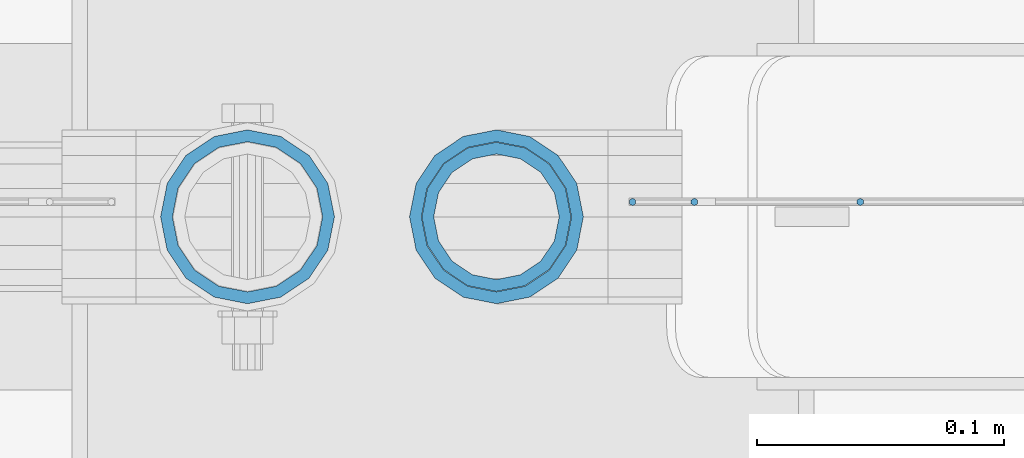
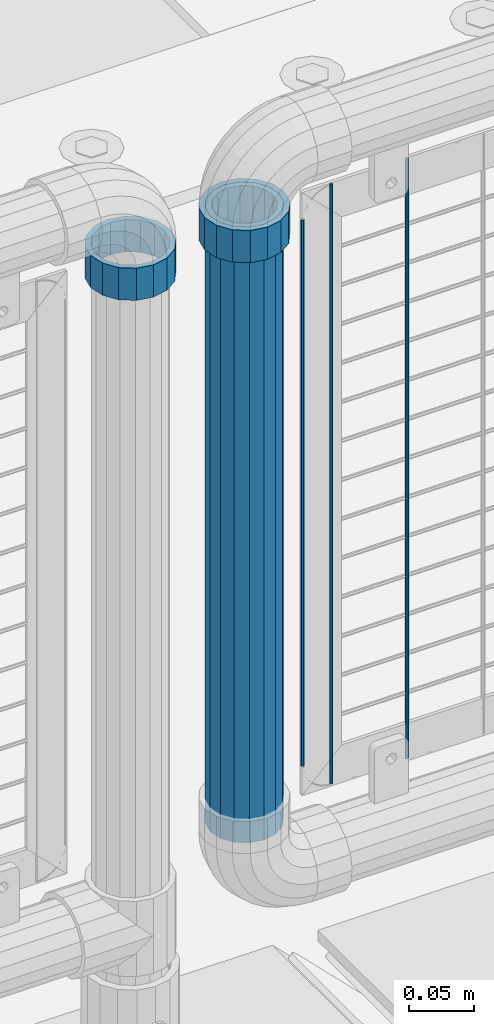
# One storey, part 98 of 257: 6 columns.
"""IFC2X3 building model written with IfcOpenShell, lengths in millimetres."""

from ifc_helpers import new_model, si_unit, frame, origin_with_axes, place, context, subcontext, project, spatial, faceted_brep, material, type_object, element, save


model = new_model("IFC2X3")

# Units and contexts
model_context = context("Model", 3, precision=1e-05, world=origin_with_axes())
body_context = subcontext(model_context, "Body", "Model", "MODEL_VIEW")
ifc_project = project(units=[si_unit("LENGTHUNIT", "METRE", prefix="MILLI"), si_unit("AREAUNIT", "SQUARE_METRE"), si_unit("VOLUMEUNIT", "CUBIC_METRE"), si_unit("MASSUNIT", "GRAM", prefix="KILO"), si_unit("TIMEUNIT", "SECOND"), si_unit("PLANEANGLEUNIT", "RADIAN"), si_unit("SOLIDANGLEUNIT", "STERADIAN"), si_unit("THERMODYNAMICTEMPERATUREUNIT", "DEGREE_CELSIUS"), si_unit("LUMINOUSINTENSITYUNIT", "LUMEN")], contexts=[model_context])

# Site, building, storey
site_placement = place(None, origin_with_axes())
site = spatial("IfcSite", under=ifc_project, at=site_placement, CompositionType="ELEMENT")
building_placement = place(site_placement, origin_with_axes())
building = spatial("IfcBuilding", under=site, at=building_placement, Name="Standard", CompositionType="ELEMENT")
storey_placement = place(building_placement, origin_with_axes())
storey = spatial("IfcBuildingStorey", under=building, at=storey_placement, Name="Undefined", CompositionType="ELEMENT", Elevation=0.0)

# Columns
ifc_material_1 = material(Name="Misc_Undefined")
column_type_1 = type_object("IfcColumnType", PredefinedType="NOTDEFINED")
column_1_placement = place(storey_placement, frame((57571.61, 10664.5, 894.849999999999), z_axis=(-1.0, 0.0, 0.0), x_axis=(0.0, 0.0, 1.0)))
element("IfcColumn", 1, at=column_1_placement, inside=storey, type_object=column_type_1, material=ifc_material_1, context=body_context, shape_type="Brep", body=[
    faceted_brep([(0.0, -30.3500000000004, 0.0), (0.0, -28.0397438117179, 11.6144421722784), (30.0, -28.0397438117179, 11.6144421722805), (30.0, -30.3500000000004, 0.0), (0.0, -21.4606908090118, 21.4606908090136), (30.0, -21.4606908090118, 21.4606908090117), (0.0, -11.6144421722802, 28.0397438117143), (30.0, -11.6144421722802, 28.0397438117175), (0.0, 0.0, 30.3499999999985), (30.0, 0.0, 30.35), (0.0, 11.6144421722802, 28.0397438117143), (30.0, 11.6144421722802, 28.0397438117175), (0.0, 21.4606908090118, 21.4606908090136), (30.0, 21.4606908090118, 21.4606908090117), (0.0, 28.0397438117179, 11.6144421722784), (30.0, 28.0397438117179, 11.6144421722805), (0.0, 30.3500000000004, 0.0), (30.0, 30.3500000000004, 0.0), (0.0, 28.0397438117179, -11.6144421722784), (30.0, 28.0397438117179, -11.6144421722805), (0.0, 21.4606908090118, -21.4606908090136), (30.0, 21.4606908090118, -21.4606908090117), (0.0, 11.6144421722802, -28.0397438117143), (30.0, 11.6144421722802, -28.0397438117175), (0.0, 0.0, -30.3499999999985), (30.0, 0.0, -30.35), (0.0, -11.6144421722802, -28.0397438117143), (30.0, -11.6144421722802, -28.0397438117175), (0.0, -21.4606908090118, -21.4606908090136), (30.0, -21.4606908090118, -21.4606908090117), (0.0, -28.0397438117179, -11.6144421722784), (30.0, -28.0397438117179, -11.6144421722805), (0.0, -35.1499999999996, 0.0), (0.0, -32.4743655677721, -13.4513226476338), (30.0, -32.4743655677721, -13.4513226476329), (30.0, -35.1499999999996, 0.0), (0.0, -24.8548033587067, -24.8548033587067), (30.0, -24.8548033587067, -24.8548033587072), (0.0, -13.4513226476338, -32.4743655677739), (30.0, -13.4513226476338, -32.4743655677717), (0.0, 0.0, -35.1499999999996), (30.0, 0.0, -35.15), (0.0, 13.4513226476338, -32.4743655677739), (30.0, 13.4513226476338, -32.4743655677717), (0.0, 24.8548033587067, -24.8548033587067), (30.0, 24.8548033587067, -24.8548033587072), (0.0, 32.4743655677721, -13.4513226476338), (30.0, 32.4743655677721, -13.4513226476329), (0.0, 35.1499999999996, 0.0), (30.0, 35.1499999999996, 0.0), (0.0, 32.4743655677721, 13.4513226476338), (30.0, 32.4743655677721, 13.4513226476329), (0.0, 24.8548033587067, 24.8548033587067), (30.0, 24.8548033587067, 24.8548033587072), (0.0, 13.4513226476338, 32.4743655677739), (30.0, 13.4513226476338, 32.4743655677717), (0.0, 0.0, 35.1499999999996), (30.0, 0.0, 35.15), (0.0, -13.4513226476338, 32.4743655677739), (30.0, -13.4513226476338, 32.4743655677717), (0.0, -24.8548033587067, 24.8548033587067), (30.0, -24.8548033587067, 24.8548033587072), (0.0, -32.4743655677721, 13.4513226476338), (30.0, -32.4743655677721, 13.4513226476329)], [[[0, 1, 2, 3]], [[1, 4, 5, 2]], [[4, 6, 7, 5]], [[6, 8, 9, 7]], [[8, 10, 11, 9]], [[10, 12, 13, 11]], [[12, 14, 15, 13]], [[14, 16, 17, 15]], [[16, 18, 19, 17]], [[18, 20, 21, 19]], [[20, 22, 23, 21]], [[22, 24, 25, 23]], [[24, 26, 27, 25]], [[26, 28, 29, 27]], [[28, 30, 31, 29]], [[30, 0, 3, 31]], [[32, 33, 34, 35]], [[33, 36, 37, 34]], [[36, 38, 39, 37]], [[38, 40, 41, 39]], [[40, 42, 43, 41]], [[42, 44, 45, 43]], [[44, 46, 47, 45]], [[46, 48, 49, 47]], [[48, 50, 51, 49]], [[50, 52, 53, 51]], [[52, 54, 55, 53]], [[54, 56, 57, 55]], [[56, 58, 59, 57]], [[58, 60, 61, 59]], [[60, 62, 63, 61]], [[62, 32, 35, 63]], [[37, 39, 41, 43, 45, 47, 49, 51, 53, 55, 57, 59, 61, 63, 35, 34], [5, 7, 9, 11, 13, 15, 17, 19, 21, 23, 25, 27, 29, 31, 3, 2]], [[62, 60, 58, 56, 54, 52, 50, 48, 46, 44, 42, 40, 38, 36, 33, 32], [30, 28, 26, 24, 22, 20, 18, 16, 14, 12, 10, 8, 6, 4, 1, 0]]]),
])
column_2_placement = place(storey_placement, frame((57471.0, 10664.5, 894.85), z_axis=(1.0, 0.0, 0.0), x_axis=(0.0, 0.0, 1.0)))
element("IfcColumn", 2, at=column_2_placement, inside=storey, type_object=column_type_1, material=ifc_material_1, context=body_context, shape_type="Brep", body=[
    faceted_brep([(0.0, -30.3500000000004, 0.0), (0.0, -28.0397438117179, 11.6144421722784), (30.0, -28.0397438117179, 11.6144421722805), (30.0, -30.3500000000004, 0.0), (0.0, -21.4606908090118, 21.4606908090136), (30.0, -21.4606908090118, 21.4606908090117), (0.0, -11.6144421722802, 28.0397438117143), (30.0, -11.6144421722802, 28.0397438117175), (0.0, 0.0, 30.3499999999985), (30.0, 0.0, 30.35), (0.0, 11.6144421722802, 28.0397438117143), (30.0, 11.6144421722802, 28.0397438117175), (0.0, 21.4606908090118, 21.4606908090136), (30.0, 21.4606908090118, 21.4606908090117), (0.0, 28.0397438117179, 11.6144421722784), (30.0, 28.0397438117179, 11.6144421722805), (0.0, 30.3500000000004, 0.0), (30.0, 30.3500000000004, 0.0), (0.0, 28.0397438117179, -11.6144421722784), (30.0, 28.0397438117179, -11.6144421722805), (0.0, 21.4606908090118, -21.4606908090136), (30.0, 21.4606908090118, -21.4606908090117), (0.0, 11.6144421722802, -28.0397438117143), (30.0, 11.6144421722802, -28.0397438117175), (0.0, 0.0, -30.3499999999985), (30.0, 0.0, -30.35), (0.0, -11.6144421722802, -28.0397438117143), (30.0, -11.6144421722802, -28.0397438117175), (0.0, -21.4606908090118, -21.4606908090136), (30.0, -21.4606908090118, -21.4606908090117), (0.0, -28.0397438117179, -11.6144421722784), (30.0, -28.0397438117179, -11.6144421722805), (0.0, -35.1499999999996, 0.0), (0.0, -32.4743655677721, -13.4513226476338), (30.0, -32.4743655677721, -13.4513226476329), (30.0, -35.1499999999996, 0.0), (0.0, -24.8548033587067, -24.8548033587067), (30.0, -24.8548033587067, -24.8548033587072), (0.0, -13.4513226476338, -32.4743655677739), (30.0, -13.4513226476338, -32.4743655677717), (0.0, 0.0, -35.1499999999996), (30.0, 0.0, -35.15), (0.0, 13.4513226476338, -32.4743655677739), (30.0, 13.4513226476338, -32.4743655677717), (0.0, 24.8548033587067, -24.8548033587067), (30.0, 24.8548033587067, -24.8548033587072), (0.0, 32.4743655677721, -13.4513226476338), (30.0, 32.4743655677721, -13.4513226476329), (0.0, 35.1499999999996, 0.0), (30.0, 35.1499999999996, 0.0), (0.0, 32.4743655677721, 13.4513226476338), (30.0, 32.4743655677721, 13.4513226476329), (0.0, 24.8548033587067, 24.8548033587067), (30.0, 24.8548033587067, 24.8548033587072), (0.0, 13.4513226476338, 32.4743655677739), (30.0, 13.4513226476338, 32.4743655677717), (0.0, 0.0, 35.1499999999996), (30.0, 0.0, 35.15), (0.0, -13.4513226476338, 32.4743655677739), (30.0, -13.4513226476338, 32.4743655677717), (0.0, -24.8548033587067, 24.8548033587067), (30.0, -24.8548033587067, 24.8548033587072), (0.0, -32.4743655677721, 13.4513226476338), (30.0, -32.4743655677721, 13.4513226476329)], [[[0, 1, 2, 3]], [[1, 4, 5, 2]], [[4, 6, 7, 5]], [[6, 8, 9, 7]], [[8, 10, 11, 9]], [[10, 12, 13, 11]], [[12, 14, 15, 13]], [[14, 16, 17, 15]], [[16, 18, 19, 17]], [[18, 20, 21, 19]], [[20, 22, 23, 21]], [[22, 24, 25, 23]], [[24, 26, 27, 25]], [[26, 28, 29, 27]], [[28, 30, 31, 29]], [[30, 0, 3, 31]], [[32, 33, 34, 35]], [[33, 36, 37, 34]], [[36, 38, 39, 37]], [[38, 40, 41, 39]], [[40, 42, 43, 41]], [[42, 44, 45, 43]], [[44, 46, 47, 45]], [[46, 48, 49, 47]], [[48, 50, 51, 49]], [[50, 52, 53, 51]], [[52, 54, 55, 53]], [[54, 56, 57, 55]], [[56, 58, 59, 57]], [[58, 60, 61, 59]], [[60, 62, 63, 61]], [[62, 32, 35, 63]], [[37, 39, 41, 43, 45, 47, 49, 51, 53, 55, 57, 59, 61, 63, 35, 34], [5, 7, 9, 11, 13, 15, 17, 19, 21, 23, 25, 27, 29, 31, 3, 2]], [[62, 60, 58, 56, 54, 52, 50, 48, 46, 44, 42, 40, 38, 36, 33, 32], [30, 28, 26, 24, 22, 20, 18, 16, 14, 12, 10, 8, 6, 4, 1, 0]]]),
])
ifc_material_2 = material()
column_type_2 = type_object("IfcColumnType", PredefinedType="NOTDEFINED")
column_3_placement = place(storey_placement, frame((57571.61, 10664.5, 349.86), z_axis=(-1.0, 0.0, 0.0), x_axis=(0.0, 0.0, 1.0)))
element("IfcColumn", 3, at=column_3_placement, inside=storey, type_object=column_type_2, material=ifc_material_2, context=body_context, shape_type="Brep", body=[
    faceted_brep([(0.0, -25.3500000000004, 0.0), (0.0, -23.4203461491616, 9.70102501045767), (574.992910334213, -23.4203461491616, 9.70102501045767), (574.990000024649, -25.3500000000004, 0.0), (0.0, -17.9251569030785, 17.9251569030821), (574.995377579387, -17.9251569030785, 17.9251569030821), (0.0, -9.70102501045585, 23.4203461491634), (574.997026144459, -9.70102501045585, 23.4203461491634), (0.0, 0.0, 25.3499999999985), (574.997605050341, 0.0, 25.3499999999985), (0.0, 9.70102501045585, 23.4203461491634), (574.997026163861, 9.70102501045585, 23.4203461491634), (0.0, 17.9251569030785, 17.9251569030821), (574.995377615237, 17.9251569030785, 17.9251569030821), (0.0, 23.4203461491616, 9.70102501045767), (574.992910381054, 23.4203461491616, 9.70102501045767), (0.0, 25.3500000000004, 0.0), (574.990000075349, 25.3500000000004, 0.0), (0.0, 23.4203461491616, -9.70102501045767), (574.987089765785, 23.4203461491616, -9.70102501045767), (0.0, 17.9251569030785, -17.9251569030821), (574.984622520612, 17.9251569030785, -17.9251569030821), (0.0, 9.70102501045585, -23.4203461491634), (574.982973955539, 9.70102501045585, -23.4203461491634), (0.0, 0.0, -25.3499999999985), (574.982395049657, 0.0, -25.3499999999985), (0.0, -9.70102501045585, -23.4203461491634), (574.982973936137, -9.70102501045585, -23.4203461491634), (0.0, -17.9251569030785, -17.9251569030821), (574.984622484761, -17.9251569030785, -17.9251569030821), (0.0, -23.4203461491616, -9.70102501045767), (574.987089718945, -23.4203461491616, -9.70102501045767), (0.0, -30.1499999999996, 0.0), (0.0, -27.8549679052157, -11.5379054858058), (574.986538650343, -27.8549679052157, -11.5379054858058), (574.990000019849, -30.1499999999996, 0.0), (0.0, -21.3192694527752, -21.3192694527752), (574.983604247556, -21.3192694527752, -21.3192694527752), (0.0, -11.5379054858076, -27.8549679052157), (574.981643547714, -11.5379054858076, -27.8549679052157), (0.0, 0.0, -30.1500000000015), (574.980955049592, 0.0, -30.1500000000015), (0.0, 11.5379054858076, -27.8549679052157), (574.98164357079, 11.5379054858076, -27.8549679052157), (0.0, 21.3192694527752, -21.3192694527752), (574.983604290195, 21.3192694527752, -21.3192694527752), (0.0, 27.8549679052157, -11.5379054858058), (574.986538706053, 27.8549679052157, -11.5379054858058), (0.0, 30.1499999999996, 0.0), (574.990000080149, 30.1499999999996, 0.0), (0.0, 27.8549679052157, 11.5379054858058), (574.993461449656, 27.8549679052157, 11.5379054858058), (0.0, 21.3192694527752, 21.3192694527752), (574.996395852442, 21.3192694527752, 21.3192694527752), (0.0, 11.5379054858076, 27.8549679052157), (574.998356552285, 11.5379054858076, 27.8549679052157), (0.0, 0.0, 30.1500000000015), (574.999045050406, 0.0, 30.1500000000015), (0.0, -11.5379054858076, 27.8549679052157), (574.998356529209, -11.5379054858076, 27.8549679052157), (0.0, -21.3192694527752, 21.3192694527752), (574.996395809804, -21.3192694527752, 21.3192694527752), (0.0, -27.8549679052157, 11.5379054858058), (574.993461393946, -27.8549679052157, 11.5379054858058)], [[[0, 1, 2, 3]], [[1, 4, 5, 2]], [[4, 6, 7, 5]], [[6, 8, 9, 7]], [[8, 10, 11, 9]], [[10, 12, 13, 11]], [[12, 14, 15, 13]], [[14, 16, 17, 15]], [[16, 18, 19, 17]], [[18, 20, 21, 19]], [[20, 22, 23, 21]], [[22, 24, 25, 23]], [[24, 26, 27, 25]], [[26, 28, 29, 27]], [[28, 30, 31, 29]], [[30, 0, 3, 31]], [[32, 33, 34, 35]], [[33, 36, 37, 34]], [[36, 38, 39, 37]], [[38, 40, 41, 39]], [[40, 42, 43, 41]], [[42, 44, 45, 43]], [[44, 46, 47, 45]], [[46, 48, 49, 47]], [[48, 50, 51, 49]], [[50, 52, 53, 51]], [[52, 54, 55, 53]], [[54, 56, 57, 55]], [[56, 58, 59, 57]], [[58, 60, 61, 59]], [[60, 62, 63, 61]], [[62, 32, 35, 63]], [[37, 39, 41, 43, 45, 47, 49, 51, 53, 55, 57, 59, 61, 63, 35, 34], [5, 7, 9, 11, 13, 15, 17, 19, 21, 23, 25, 27, 29, 31, 3, 2]], [[62, 60, 58, 56, 54, 52, 50, 48, 46, 44, 42, 40, 38, 36, 33, 32], [30, 28, 26, 24, 22, 20, 18, 16, 14, 12, 10, 8, 6, 4, 1, 0]]]),
])
column_type_3 = type_object("IfcColumnType", Name="D3", PredefinedType="NOTDEFINED")
column_4_placement = place(storey_placement, frame((57718.638, 10670.4999688155, 353.02), z_axis=(-1.0, 0.0, 0.0), x_axis=(0.0, 0.0, 1.0)))
element("IfcColumn", 4, at=column_4_placement, inside=storey, type_object=column_type_3, material=ifc_material_1, ObjectType="D3", context=body_context, shape_type="Brep", body=[
    faceted_brep([(0.0, -1.5, -5.6843418860808e-14), (0.0, -0.750000000001819, -1.29903810567669), (560.0, -0.75, -1.29903810567339), (560.0, -1.5, 0.0), (7.27595761418343e-12, 0.749999999998181, -1.29903810567669), (560.0, 0.75, -1.29903810567339), (0.0, 1.5, -5.6843418860808e-14), (560.0, 1.5, 0.0), (7.27595761418343e-12, 0.749999999998181, 1.29903810567669), (560.0, 0.75, 1.29903810567339), (0.0, -0.750000000001819, 1.29903810567669), (560.0, -0.75, 1.29903810567339)], [[[0, 1, 2, 3]], [[1, 4, 5, 2]], [[4, 6, 7, 5]], [[6, 8, 9, 7]], [[8, 10, 11, 9]], [[10, 0, 3, 11]], [[5, 7, 9, 11, 3, 2]], [[10, 8, 6, 4, 1, 0]]]),
])
column_5_placement = place(storey_placement, frame((57626.61, 10670.4999883292, 378.02), z_axis=(-1.0, 0.0, 0.0), x_axis=(0.0, 0.0, 1.0)))
element("IfcColumn", 5, at=column_5_placement, inside=storey, type_object=column_type_3, material=ifc_material_1, ObjectType="D3", context=body_context, shape_type="Brep", body=[
    faceted_brep([(0.0, -1.5, -5.6843418860808e-14), (0.0, -0.750000000001819, -1.29903810567669), (510.0, -0.75, -1.29903810567339), (510.0, -1.5, 0.0), (7.27595761418343e-12, 0.749999999998181, -1.29903810567669), (510.0, 0.75, -1.29903810567339), (0.0, 1.5, -5.6843418860808e-14), (510.0, 1.5, 0.0), (7.27595761418343e-12, 0.749999999998181, 1.29903810567669), (510.0, 0.75, 1.29903810567339), (0.0, -0.750000000001819, 1.29903810567669), (510.0, -0.75, 1.29903810567339)], [[[0, 1, 2, 3]], [[1, 4, 5, 2]], [[4, 6, 7, 5]], [[6, 8, 9, 7]], [[8, 10, 11, 9]], [[10, 0, 3, 11]], [[5, 7, 9, 11, 3, 2]], [[10, 8, 6, 4, 1, 0]]]),
])
column_6_placement = place(storey_placement, frame((57651.61, 10670.4999830243, 353.02), z_axis=(-1.0, 0.0, 0.0), x_axis=(0.0, 0.0, 1.0)))
element("IfcColumn", 6, at=column_6_placement, inside=storey, type_object=column_type_3, material=ifc_material_1, ObjectType="D3", context=body_context, shape_type="Brep", body=[
    faceted_brep([(0.0, -1.5, -5.6843418860808e-14), (0.0, -0.750000000001819, -1.29903810567669), (560.0, -0.75, -1.29903810567339), (560.0, -1.5, 0.0), (7.27595761418343e-12, 0.749999999998181, -1.29903810567669), (560.0, 0.75, -1.29903810567339), (0.0, 1.5, -5.6843418860808e-14), (560.0, 1.5, 0.0), (7.27595761418343e-12, 0.749999999998181, 1.29903810567669), (560.0, 0.75, 1.29903810567339), (0.0, -0.750000000001819, 1.29903810567669), (560.0, -0.75, 1.29903810567339)], [[[0, 1, 2, 3]], [[1, 4, 5, 2]], [[4, 6, 7, 5]], [[6, 8, 9, 7]], [[8, 10, 11, 9]], [[10, 0, 3, 11]], [[5, 7, 9, 11, 3, 2]], [[10, 8, 6, 4, 1, 0]]]),
])

save(model, "model.ifc")
